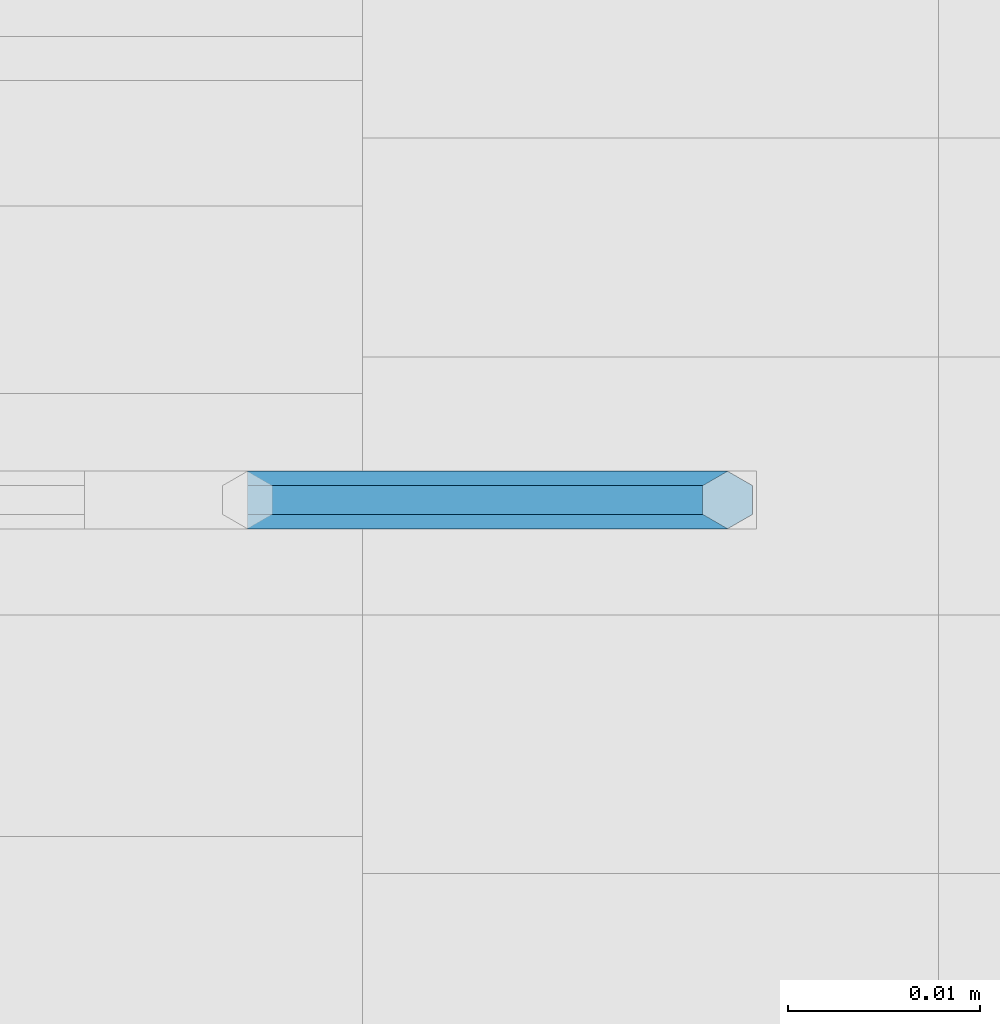
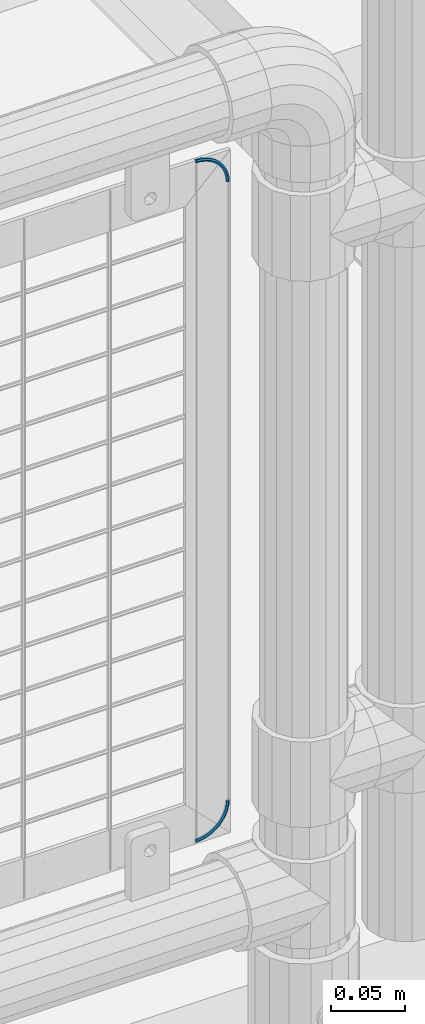
# One storey, part 183 of 240: 2 members.
"""IFC2X3 building model written with IfcOpenShell, lengths in millimetres."""

from ifc_helpers import new_model, si_unit, frame, origin_with_axes, place, context, subcontext, project, spatial, faceted_brep, material, type_object, element, save


model = new_model("IFC2X3")

# Units and contexts
model_context = context("Model", 3, precision=1e-05, world=origin_with_axes())
body_context = subcontext(model_context, "Body", "Model", "MODEL_VIEW")
ifc_project = project(units=[si_unit("LENGTHUNIT", "METRE", prefix="MILLI"), si_unit("AREAUNIT", "SQUARE_METRE"), si_unit("VOLUMEUNIT", "CUBIC_METRE"), si_unit("MASSUNIT", "GRAM", prefix="KILO"), si_unit("TIMEUNIT", "SECOND"), si_unit("PLANEANGLEUNIT", "RADIAN"), si_unit("SOLIDANGLEUNIT", "STERADIAN"), si_unit("THERMODYNAMICTEMPERATUREUNIT", "DEGREE_CELSIUS"), si_unit("LUMINOUSINTENSITYUNIT", "LUMEN")], contexts=[model_context])

# Site, building, storey
site_placement = place(None, origin_with_axes())
site = spatial("IfcSite", under=ifc_project, at=site_placement, CompositionType="ELEMENT")
building_placement = place(site_placement, origin_with_axes())
building = spatial("IfcBuilding", under=site, at=building_placement, Name="Standard", CompositionType="ELEMENT")
storey_placement = place(building_placement, origin_with_axes())
storey = spatial("IfcBuildingStorey", under=building, at=storey_placement, Name="Undefined", CompositionType="ELEMENT", Elevation=0.0)

# Members
ifc_material = material(Name="Misc_Undefined")
member_type = type_object("IfcMemberType", Name="D3", PredefinedType="NOTDEFINED")
member_1_placement = place(storey_placement, frame((55825.0000000001, 34670.4997788013, 888.02), z_axis=(0.707106781186541, -1.49999999888231e-07, 0.707106781186538), x_axis=(-0.707106781186548, 0.0, 0.707106781186548)))
element("IfcMember", 1, at=member_1_placement, inside=storey, type_object=member_type, material=ifc_material, ObjectType="D3", context=body_context, shape_type="Brep", body=[
    faceted_brep([(-7.27595761418343e-12, -1.49999999999272, 0.0), (0.918558653545915, -0.750000000007276, -0.918558653538639), (3.74659366302512, -0.75, 1.49681142588088), (2.98303822235175, -1.50000000000728, 2.54775532971689), (0.918558653545915, 0.749999999992724, -0.918558653538639), (3.74659366302512, 0.75, 1.49681142588088), (0.0, 1.50000000000728, 0.0), (2.98303822235175, 1.49999999999272, 2.54775532970962), (-0.918558653545915, 0.75, 0.918558653545915), (2.21948278166383, 0.75, 3.59869923354563), (-0.918558653545915, -0.75, 0.918558653545915), (2.21948278166383, -0.75, 3.59869923354563), (6.91765799494897, -0.75, 3.44004214772576), (6.32790703617502, -1.5, 4.59749357504188), (6.91765799494169, 0.75, 3.44004214772576), (6.32790703617502, 1.5, 4.59749357504188), (5.7381560773938, 0.75, 5.75494500237983), (5.7381560773938, -0.75, 5.75494500237983), (10.3536695212824, -0.75, 4.86328472239984), (9.95224467029038, -1.5, 6.09874337771907), (10.3536695212824, 0.75, 4.86328472239984), (9.95224467028311, 1.5, 6.09874337771907), (9.55081981929834, 0.75, 7.33420203303831), (9.55081981929834, -0.75, 7.33420203303831), (13.9700222347819, -0.75, 5.73149419425317), (13.7668079036521, -1.50000000000728, 7.01453898521868), (13.9700222347819, 0.75, 5.7314941942459), (13.7668079036521, 1.49999999999272, 7.0145389852114), (13.5635935725295, 0.75, 8.29758377619146), (13.5635935725295, -0.75, 8.29758377619146), (17.6776695296576, -0.750000000007276, 6.02329236466903), (17.6776695296649, -1.5, 7.32233047034242), (17.6776695296576, 0.749999999992724, 6.02329236466176), (17.6776695296649, 1.5, 7.32233047033515), (17.6776695296649, 0.75, 8.62136857601581), (17.6776695296649, -0.75, 8.62136857601581), (21.3853168245405, -0.750000000007276, 5.73149419426045), (21.5885311556631, -1.5, 7.01453898521868), (21.3853168245405, 0.749999999992724, 5.73149419425317), (21.5885311556704, 1.5, 7.01453898521868), (21.7917454867929, 0.75, 8.29758377617691), (21.7917454867929, -0.75, 8.29758377618418), (25.0016695380327, -0.750000000007276, 4.86328472239984), (25.403094389032, -1.5, 6.09874337771907), (25.0016695380327, 0.749999999992724, 4.86328472239256), (25.4030943890393, 1.5, 6.09874337771907), (25.8045192400314, 0.75, 7.33420203303831), (25.8045192400314, -0.75, 7.33420203304559), (28.4376810643735, -0.75, 3.44004214771849), (29.0274320231547, -1.50000000000728, 4.59749357504916), (28.4376810643735, 0.75, 3.44004214771121), (29.0274320231547, 1.49999999999272, 4.59749357504188), (29.6171829819286, 0.75, 5.75494500237255), (29.6171829819286, -0.75, 5.75494500237983), (31.60874539629, -0.750000000007276, 1.49681142588815), (32.3723008369707, -1.5, 2.54775532971689), (31.60874539629, 0.749999999992724, 1.49681142588088), (32.372300836978, 1.5, 2.54775532970962), (33.1358562776586, 0.75, 3.59869923354563), (33.1358562776586, -0.75, 3.59869923355291), (34.4367804057838, -0.75, -0.918558653545915), (35.3553390593224, -1.5, 7.27595761418343e-12), (34.4367804057765, 0.75, -0.918558653545915), (35.3553390593297, 1.5, 0.0), (36.2738977128611, 0.75, 0.918558653545915), (36.2738977128683, -0.75, 0.918558653545915)], [[[0, 1, 2, 3]], [[1, 4, 5, 2]], [[4, 6, 7, 5]], [[6, 8, 9, 7]], [[8, 10, 11, 9]], [[10, 0, 3, 11]], [[10, 8, 6, 4, 1, 0]], [[3, 2, 12, 13]], [[2, 5, 14, 12]], [[5, 7, 15, 14]], [[7, 9, 16, 15]], [[9, 11, 17, 16]], [[11, 3, 13, 17]], [[13, 12, 18, 19]], [[12, 14, 20, 18]], [[14, 15, 21, 20]], [[15, 16, 22, 21]], [[16, 17, 23, 22]], [[17, 13, 19, 23]], [[19, 18, 24, 25]], [[18, 20, 26, 24]], [[20, 21, 27, 26]], [[21, 22, 28, 27]], [[22, 23, 29, 28]], [[23, 19, 25, 29]], [[25, 24, 30, 31]], [[24, 26, 32, 30]], [[26, 27, 33, 32]], [[27, 28, 34, 33]], [[28, 29, 35, 34]], [[29, 25, 31, 35]], [[31, 30, 36, 37]], [[30, 32, 38, 36]], [[32, 33, 39, 38]], [[33, 34, 40, 39]], [[34, 35, 41, 40]], [[35, 31, 37, 41]], [[37, 36, 42, 43]], [[36, 38, 44, 42]], [[38, 39, 45, 44]], [[39, 40, 46, 45]], [[40, 41, 47, 46]], [[41, 37, 43, 47]], [[43, 42, 48, 49]], [[42, 44, 50, 48]], [[44, 45, 51, 50]], [[45, 46, 52, 51]], [[46, 47, 53, 52]], [[47, 43, 49, 53]], [[49, 48, 54, 55]], [[48, 50, 56, 54]], [[50, 51, 57, 56]], [[51, 52, 58, 57]], [[52, 53, 59, 58]], [[53, 49, 55, 59]], [[55, 54, 60, 61]], [[54, 56, 62, 60]], [[56, 57, 63, 62]], [[57, 58, 64, 63]], [[58, 59, 65, 64]], [[59, 55, 61, 65]], [[62, 63, 64, 65, 61, 60]]]),
])
member_2_placement = place(storey_placement, frame((55825.0000000001, 34670.4997788013, 378.02), z_axis=(-0.707106781186548, 0.0, 0.707106781186548), x_axis=(-0.707106781186548, 0.0, -0.707106781186548)))
element("IfcMember", 2, at=member_2_placement, inside=storey, type_object=member_type, material=ifc_material, ObjectType="D3", context=body_context, shape_type="Brep", body=[
    faceted_brep([(-7.27595761418343e-12, -1.49999999999272, 0.0), (-0.918558653545915, -0.749999999992724, -0.918558653545915), (2.21948278166383, -0.749999999992724, -3.59869923354563), (2.98303822235903, -1.5, -2.54775532971689), (-0.918558653545915, 0.750000000007276, -0.918558653545915), (2.21948278166383, 0.750000000007276, -3.59869923354563), (0.0, 1.50000000000728, 0.0), (2.98303822235175, 1.5, -2.54775532970962), (0.918558653545915, 0.75, 0.918558653538639), (3.7465936630324, 0.750000000007276, -1.49681142588088), (0.918558653545915, -0.75, 0.918558653538639), (3.7465936630324, -0.749999999992724, -1.49681142588088), (5.73815607740107, -0.749999999992724, -5.75494500237983), (6.32790703617502, -1.49999999999272, -4.59749357505643), (5.7381560773938, 0.750000000007276, -5.75494500237983), (6.32790703617502, 1.50000000000728, -4.59749357504916), (6.91765799494897, 0.750000000007276, -3.44004214772576), (6.91765799494897, -0.749999999992724, -3.44004214772576), (9.55081981929834, -0.749999999992724, -7.33420203303831), (9.95224467029038, -1.49999999999272, -6.09874337771907), (9.55081981929834, 0.750000000007276, -7.33420203303831), (9.95224467028311, 1.50000000000728, -6.09874337771907), (10.3536695212897, 0.750000000007276, -4.86328472240712), (10.3536695212897, -0.749999999992724, -4.86328472239984), (13.5635935725295, -0.749999999992724, -8.29758377619146), (13.7668079036594, -1.5, -7.01453898522595), (13.5635935725295, 0.750000000007276, -8.29758377619146), (13.7668079036594, 1.5, -7.01453898521868), (13.9700222347819, 0.750000000007276, -5.7314941942459), (13.9700222347819, -0.749999999992724, -5.73149419425317), (17.6776695296576, -0.749999999992724, -8.62136857602309), (17.6776695296649, -1.49999999999272, -7.32233047034242), (17.6776695296576, 0.750000000007276, -8.62136857601581), (17.6776695296576, 1.50000000000728, -7.32233047033515), (17.6776695296649, 0.75, -6.02329236466176), (17.6776695296649, -0.75, -6.02329236466903), (21.7917454868002, -0.749999999992724, -8.29758377618418), (21.5885311556704, -1.49999999999272, -7.01453898522595), (21.7917454867929, 0.750000000007276, -8.29758377617691), (21.5885311556776, 1.50000000000728, -7.01453898521868), (21.3853168245478, 0.75, -5.73149419425317), (21.3853168245478, -0.75, -5.73149419426045), (25.8045192400314, -0.749999999992724, -7.33420203304559), (25.4030943890393, -1.49999999999272, -6.09874337772635), (25.8045192400314, 0.750000000007276, -7.33420203303831), (25.4030943890466, 1.50000000000728, -6.09874337771907), (25.00166953804, 0.75, -4.86328472239256), (25.00166953804, -0.75, -4.86328472239984), (29.6171829819286, -0.749999999992724, -5.75494500237983), (29.0274320231474, -1.5, -4.59749357504916), (29.6171829819286, 0.750000000007276, -5.75494500237255), (29.0274320231547, 1.5, -4.59749357504188), (28.4376810643735, 0.750000000007276, -3.44004214771849), (28.4376810643735, -0.749999999992724, -3.44004214772576), (33.1358562776659, -0.749999999992724, -3.59869923355291), (32.372300836978, -1.49999999999272, -2.54775532971689), (33.1358562776659, 0.750000000007276, -3.59869923354563), (32.3723008369852, 1.50000000000728, -2.54775532971689), (31.60874539629, 0.75, -1.49681142588088), (31.6087453962973, -0.75, -1.49681142588815), (36.2738977128756, -0.749999999992724, -0.918558653553191), (35.3553390593224, -1.5, 7.27595761418343e-12), (36.2738977128683, 0.750000000007276, -0.918558653545915), (35.3553390593297, 1.5, 0.0), (34.4367804057765, 0.750000000007276, 0.918558653545915), (34.4367804057838, -0.749999999992724, 0.918558653538639)], [[[0, 1, 2, 3]], [[1, 4, 5, 2]], [[4, 6, 7, 5]], [[6, 8, 9, 7]], [[8, 10, 11, 9]], [[10, 0, 3, 11]], [[10, 8, 6, 4, 1, 0]], [[3, 2, 12, 13]], [[2, 5, 14, 12]], [[5, 7, 15, 14]], [[7, 9, 16, 15]], [[9, 11, 17, 16]], [[11, 3, 13, 17]], [[13, 12, 18, 19]], [[12, 14, 20, 18]], [[14, 15, 21, 20]], [[15, 16, 22, 21]], [[16, 17, 23, 22]], [[17, 13, 19, 23]], [[19, 18, 24, 25]], [[18, 20, 26, 24]], [[20, 21, 27, 26]], [[21, 22, 28, 27]], [[22, 23, 29, 28]], [[23, 19, 25, 29]], [[25, 24, 30, 31]], [[24, 26, 32, 30]], [[26, 27, 33, 32]], [[27, 28, 34, 33]], [[28, 29, 35, 34]], [[29, 25, 31, 35]], [[31, 30, 36, 37]], [[30, 32, 38, 36]], [[32, 33, 39, 38]], [[33, 34, 40, 39]], [[34, 35, 41, 40]], [[35, 31, 37, 41]], [[37, 36, 42, 43]], [[36, 38, 44, 42]], [[38, 39, 45, 44]], [[39, 40, 46, 45]], [[40, 41, 47, 46]], [[41, 37, 43, 47]], [[43, 42, 48, 49]], [[42, 44, 50, 48]], [[44, 45, 51, 50]], [[45, 46, 52, 51]], [[46, 47, 53, 52]], [[47, 43, 49, 53]], [[49, 48, 54, 55]], [[48, 50, 56, 54]], [[50, 51, 57, 56]], [[51, 52, 58, 57]], [[52, 53, 59, 58]], [[53, 49, 55, 59]], [[55, 54, 60, 61]], [[54, 56, 62, 60]], [[56, 57, 63, 62]], [[57, 58, 64, 63]], [[58, 59, 65, 64]], [[59, 55, 61, 65]], [[62, 63, 64, 65, 61, 60]]]),
])

save(model, "model.ifc")
